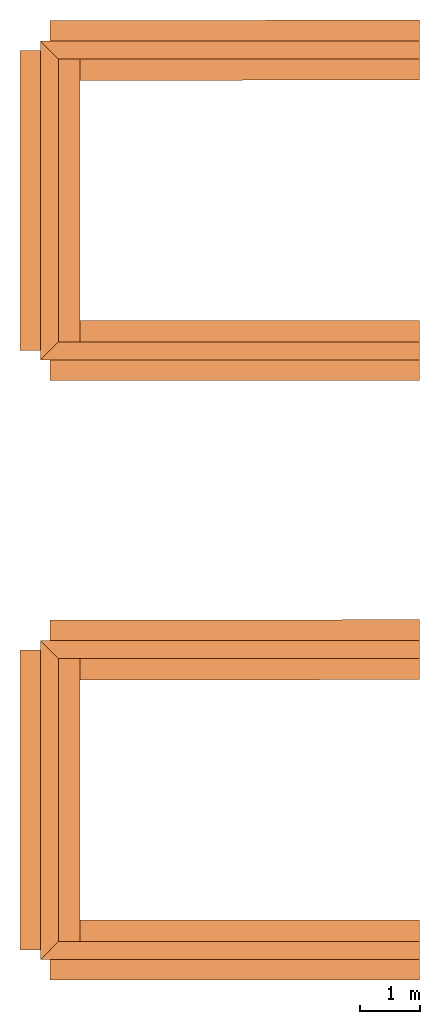
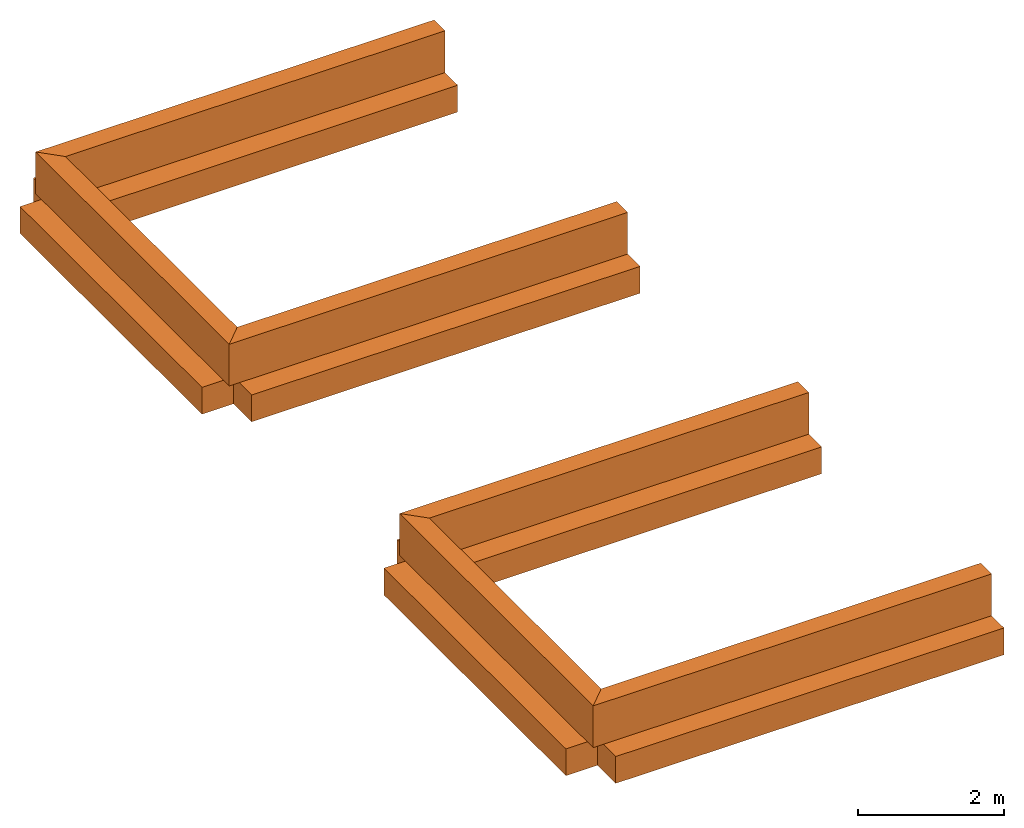
# One storey: 12 proxies.
"""IFC2X3 building model written with IfcOpenShell, lengths in metres."""

from ifc_helpers import new_model, entity, si_unit, converted_unit, derived_unit, money_unit, direction, frame, frame_2d, origin_with_axes, place, context, subcontext, project, spatial, polyline, rectangle, outline, extrude, material, type_object, element, save


model = new_model("IFC2X3")

# Units and contexts
model_context = context("Model", 3, precision=1e-05, world=origin_with_axes(), true_north=direction((0.0, 1.0)))
body_context = subcontext(model_context, "Body", "Model", "MODEL_VIEW")
ifc_project = project(units=[si_unit("LENGTHUNIT", "METRE"), si_unit("AREAUNIT", "SQUARE_METRE"), si_unit("VOLUMEUNIT", "CUBIC_METRE"), converted_unit("PLANEANGLEUNIT", "DEGREE", entity("IfcPlaneAngleMeasure", 0.0174532925199433), si_unit("PLANEANGLEUNIT", "RADIAN"), dimensions=[0, 0, 0, 0, 0, 0, 0]), money_unit("EUR"), converted_unit("TIMEUNIT", "Year", entity("IfcTimeMeasure", 31557600.0), si_unit("TIMEUNIT", "SECOND"), dimensions=[0, 0, 1, 0, 0, 0, 0]), si_unit("MASSUNIT", "GRAM", prefix="KILO"), si_unit("THERMODYNAMICTEMPERATUREUNIT", "DEGREE_CELSIUS"), si_unit("LUMINOUSINTENSITYUNIT", "LUMEN"), si_unit("ENERGYUNIT", "JOULE", prefix="MEGA"), derived_unit("THERMALCONDUCTANCEUNIT", [(si_unit("POWERUNIT", "WATT"), 1), (si_unit("LENGTHUNIT", "METRE"), -1), (si_unit("THERMODYNAMICTEMPERATUREUNIT", "KELVIN"), -1)]), derived_unit("SPECIFICHEATCAPACITYUNIT", [(si_unit("ENERGYUNIT", "JOULE"), 1), (si_unit("MASSUNIT", "GRAM", prefix="KILO"), -1), (si_unit("THERMODYNAMICTEMPERATUREUNIT", "KELVIN"), -1)]), derived_unit("MASSDENSITYUNIT", [(si_unit("MASSUNIT", "GRAM", prefix="KILO"), 1), (si_unit("VOLUMEUNIT", "CUBIC_METRE"), -1)])], contexts=[model_context])

# Site, building, storey
site_placement = place(None, origin_with_axes())
site = spatial("IfcSite", under=ifc_project, at=site_placement, CompositionType="ELEMENT")
building_placement = place(site_placement, origin_with_axes())
building = spatial("IfcBuilding", under=site, at=building_placement, Name="Edificio", CompositionType="ELEMENT")
storey_placement = place(building_placement, frame((0.0, 0.0, -1.0), z_axis=(0.0, 0.0, 1.0), x_axis=(1.0, 0.0, 0.0)))
storey = spatial("IfcBuildingStorey", under=building, at=storey_placement, Name="B01", CompositionType="ELEMENT", Elevation=-1.0)

# Proxies
ifc_material = material(Name="Cemento Strutturale")
building_element_proxy_type_1 = type_object("IfcBuildingElementProxyType", Name="Cemento Strutturale 300", PredefinedType="NOTDEFINED")
proxy_1_placement = place(storey_placement, frame((-0.16, -0.16, 0.0), z_axis=(0.0, 0.0, 1.0), x_axis=(1.0, 0.0, 0.0)))
element("IfcBuildingElementProxy", 1, at=proxy_1_placement, inside=storey, type_object=building_element_proxy_type_1, material=ifc_material, Name="MUR_004", context=body_context, shape_type="SweptSolid", body=[
    extrude(outline(polyline([(0.0, 0.0), (6.32, 0.0), (6.32, 0.2999999999999999), (0.2999999999999997, 0.2999999999999999), (0.0, 0.0)])), origin_with_axes(), (0.0, 0.0, 1.0), 0.7000000000000004),
])
proxy_2_placement = place(storey_placement, frame((-0.16, 5.16, 0.0), z_axis=(0.0, 0.0, 1.0), x_axis=(0.0, -1.0, 0.0)))
element("IfcBuildingElementProxy", 2, at=proxy_2_placement, inside=storey, type_object=building_element_proxy_type_1, material=ifc_material, Name="MUR_005", context=body_context, shape_type="SweptSolid", body=[
    extrude(outline(polyline([(0.0, 0.0), (5.32, 0.0), (5.02, 0.3), (0.2999999999999998, 0.3), (0.0, 0.0)])), origin_with_axes(), (0.0, 0.0, 1.0), 0.7000000000000004),
])
proxy_3_placement = place(storey_placement, frame((6.16, 5.16, 0.0), z_axis=(0.0, 0.0, 1.0), x_axis=(-1.0, 0.0, 0.0)))
element("IfcBuildingElementProxy", 3, at=proxy_3_placement, inside=storey, type_object=building_element_proxy_type_1, material=ifc_material, Name="MUR_006", context=body_context, shape_type="SweptSolid", body=[
    extrude(outline(polyline([(0.0, 0.0), (6.32, 0.0), (6.02, 0.2999999999999998), (0.0, 0.2999999999999998), (0.0, 0.0)])), origin_with_axes(), (0.0, 0.0, 1.0), 0.7000000000000004),
])
proxy_4_placement = place(storey_placement, frame((-0.1599999999999991, 9.84, 0.0), z_axis=(0.0, 0.0, 1.0), x_axis=(1.0, 0.0, 0.0)))
element("IfcBuildingElementProxy", 4, at=proxy_4_placement, inside=storey, type_object=building_element_proxy_type_1, material=ifc_material, Name="MUR_015", context=body_context, shape_type="SweptSolid", body=[
    extrude(outline(polyline([(0.0, 0.0), (6.32, 0.0), (6.32, 0.3000000000000007), (0.2999999999999997, 0.3000000000000007), (0.0, 0.0)])), origin_with_axes(), (0.0, 0.0, 1.0), 0.7000000000000004),
])
proxy_5_placement = place(storey_placement, frame((-0.1599999999999991, 15.16, 0.0), z_axis=(0.0, 0.0, 1.0), x_axis=(0.0, -1.0, 0.0)))
element("IfcBuildingElementProxy", 5, at=proxy_5_placement, inside=storey, type_object=building_element_proxy_type_1, material=ifc_material, Name="MUR_016", context=body_context, shape_type="SweptSolid", body=[
    extrude(outline(polyline([(0.0, 0.0), (5.32, 0.0), (5.02, 0.3), (0.3000000000000007, 0.3), (0.0, 0.0)])), origin_with_axes(), (0.0, 0.0, 1.0), 0.7000000000000004),
])
proxy_6_placement = place(storey_placement, frame((6.160000000000001, 15.16, 0.0), z_axis=(0.0, 0.0, 1.0), x_axis=(-1.0, 0.0, 0.0)))
element("IfcBuildingElementProxy", 6, at=proxy_6_placement, inside=storey, type_object=building_element_proxy_type_1, material=ifc_material, Name="MUR_017", context=body_context, shape_type="SweptSolid", body=[
    extrude(outline(polyline([(0.0, 0.0), (6.32, 0.0), (6.02, 0.3000000000000007), (0.0, 0.3000000000000007), (0.0, 0.0)])), origin_with_axes(), (0.0, 0.0, 1.0), 0.7000000000000004),
])
building_element_proxy_type_2 = type_object("IfcBuildingElementProxyType", Name="Cemento Strutturale 1000 x 450", PredefinedType="NOTDEFINED")
proxy_7_placement = place(storey_placement, frame((6.16, 5.01, 0.0), z_axis=(0.0, 0.0, 1.0), x_axis=(-0.001623374484296532, 0.9999986823267738, 0.0)))
element("IfcBuildingElementProxy", 7, at=proxy_7_placement, inside=storey, type_object=building_element_proxy_type_2, material=ifc_material, Name="001", context=body_context, shape_type="SweptSolid", body=[
    extrude(rectangle(XDim=0.4500000054539393, YDim=1.0, at=frame_2d((-0.2250000027269697, 0.0), x_axis=(1.0, 0.0))), frame((0.0, 0.0, 0.0), z_axis=(0.0, 1.0, 0.0), x_axis=(0.0, 0.0, 1.0)), (0.0, 0.0, 1.0), 6.160008116877769),
])
proxy_8_placement = place(storey_placement, frame((0.0, 5.000000000000001, 0.0), z_axis=(0.0, 0.0, 1.0), x_axis=(-1.0, 0.0, 0.0)))
element("IfcBuildingElementProxy", 8, at=proxy_8_placement, inside=storey, type_object=building_element_proxy_type_2, material=ifc_material, Name="002", context=body_context, shape_type="SweptSolid", body=[
    extrude(rectangle(XDim=0.4500000054539393, YDim=1.0, at=frame_2d((-0.2250000027269697, 0.0), x_axis=(1.0, 0.0))), frame((0.0, 0.0, 0.0), z_axis=(0.0, 1.0, 0.0), x_axis=(0.0, 0.0, 1.0)), (0.0, 0.0, 1.0), 5.000000000000001),
])
proxy_9_placement = place(storey_placement, frame((0.0, 0.0, 0.0), z_axis=(0.0, 0.0, 1.0), x_axis=(0.0, -1.0, 0.0)))
element("IfcBuildingElementProxy", 9, at=proxy_9_placement, inside=storey, type_object=building_element_proxy_type_2, material=ifc_material, Name="003", context=body_context, shape_type="SweptSolid", body=[
    extrude(rectangle(XDim=0.4500000054539393, YDim=1.0, at=frame_2d((-0.2250000027269697, 0.0), x_axis=(1.0, 0.0))), frame((0.0, 0.0, 0.0), z_axis=(0.0, 1.0, 0.0), x_axis=(0.0, 0.0, 1.0)), (0.0, 0.0, 1.0), 6.159999999999999),
])
proxy_10_placement = place(storey_placement, frame((6.160000000000001, 15.01, 0.0), z_axis=(0.0, 0.0, 1.0), x_axis=(-0.001623374484296676, 0.9999986823267738, 0.0)))
element("IfcBuildingElementProxy", 10, at=proxy_10_placement, inside=storey, type_object=building_element_proxy_type_2, material=ifc_material, Name="004", context=body_context, shape_type="SweptSolid", body=[
    extrude(rectangle(XDim=0.4500000054539393, YDim=1.0, at=frame_2d((-0.2250000027269697, 0.0), x_axis=(1.0, 0.0))), frame((0.0, 0.0, 0.0), z_axis=(0.0, 1.0, 0.0), x_axis=(0.0, 0.0, 1.0)), (0.0, 0.0, 1.0), 6.160008116877769),
])
proxy_11_placement = place(storey_placement, frame((0.0, 15.0, 0.0), z_axis=(0.0, 0.0, 1.0), x_axis=(-1.0, 0.0, 0.0)))
element("IfcBuildingElementProxy", 11, at=proxy_11_placement, inside=storey, type_object=building_element_proxy_type_2, material=ifc_material, Name="005", context=body_context, shape_type="SweptSolid", body=[
    extrude(rectangle(XDim=0.4500000054539393, YDim=1.0, at=frame_2d((-0.2250000027269697, 0.0), x_axis=(1.0, 0.0))), frame((0.0, 0.0, 0.0), z_axis=(0.0, 1.0, 0.0), x_axis=(0.0, 0.0, 1.0)), (0.0, 0.0, 1.0), 5.0),
])
proxy_12_placement = place(storey_placement, frame((0.0, 10.0, 0.0), z_axis=(0.0, 0.0, 1.0), x_axis=(0.0, -1.0, 0.0)))
element("IfcBuildingElementProxy", 12, at=proxy_12_placement, inside=storey, type_object=building_element_proxy_type_2, material=ifc_material, Name="006", context=body_context, shape_type="SweptSolid", body=[
    extrude(rectangle(XDim=0.4500000054539393, YDim=1.0, at=frame_2d((-0.2250000027269697, 0.0), x_axis=(1.0, 0.0))), frame((0.0, 0.0, 0.0), z_axis=(0.0, 1.0, 0.0), x_axis=(0.0, 0.0, 1.0)), (0.0, 0.0, 1.0), 6.159999999999999),
])

save(model, "model.ifc")
